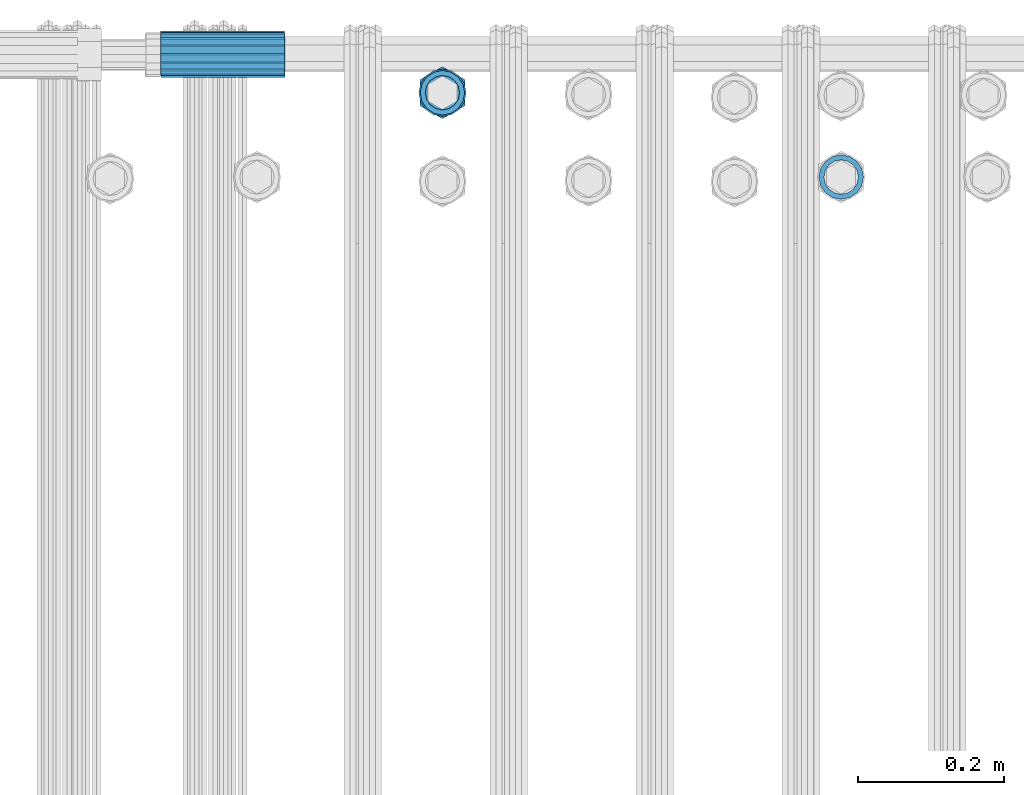
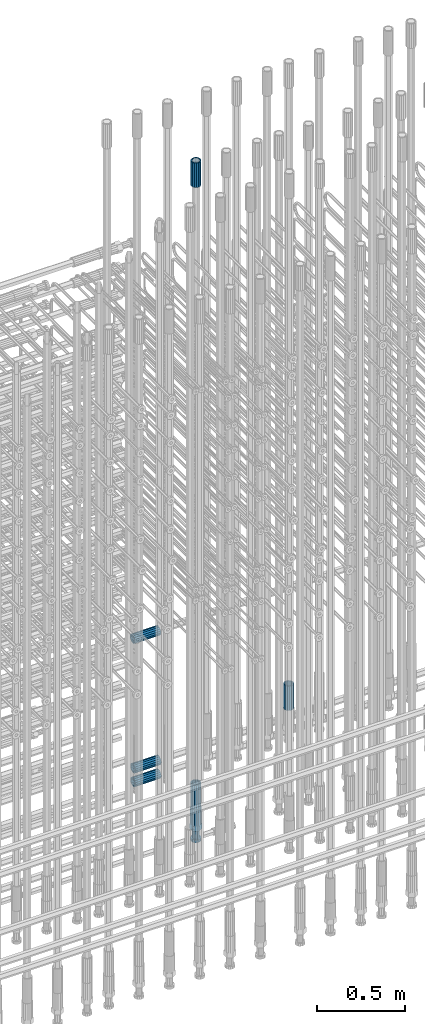
# One storey, part 70 of 177: 7 beams.
"""IFC2X3 building model written with IfcOpenShell, lengths in millimetres."""

from ifc_helpers import new_model, si_unit, frame, origin_with_axes, place, context, subcontext, project, spatial, faceted_brep, material, type_object, element, save


model = new_model("IFC2X3")

# Units and contexts
model_context_1 = context("Model", 3, precision=1e-05, world=origin_with_axes())
model_context_2 = context("Model", 3, precision=1e-05, world=origin_with_axes())
body_context = subcontext(model_context_2, "Body", "Model", "MODEL_VIEW")
ifc_project = project(units=[si_unit("LENGTHUNIT", "METRE", prefix="MILLI"), si_unit("AREAUNIT", "SQUARE_METRE"), si_unit("VOLUMEUNIT", "CUBIC_METRE"), si_unit("MASSUNIT", "GRAM", prefix="KILO"), si_unit("TIMEUNIT", "SECOND"), si_unit("PLANEANGLEUNIT", "RADIAN"), si_unit("SOLIDANGLEUNIT", "STERADIAN"), si_unit("THERMODYNAMICTEMPERATUREUNIT", "DEGREE_CELSIUS"), si_unit("LUMINOUSINTENSITYUNIT", "LUMEN")], contexts=[model_context_1])

# Site, building, storey
site_placement = place(None, origin_with_axes())
site = spatial("IfcSite", under=ifc_project, at=site_placement, CompositionType="ELEMENT")
building_placement = place(site_placement, origin_with_axes())
building = spatial("IfcBuilding", under=site, at=building_placement, Name="Undefined", CompositionType="ELEMENT")
storey_placement = place(building_placement, origin_with_axes())
storey = spatial("IfcBuildingStorey", under=building, at=storey_placement, Name="Undefined", CompositionType="ELEMENT", Elevation=0.0)

# Beams
ifc_material = material(Name="STEEL/S275")
beam_type_1 = type_object("IfcBeamType", PredefinedType="NOTDEFINED")
beam_1_placement = place(storey_placement, frame((2032235.99847313, 6206346.48588036, 18490.9668004296), z_axis=(-1.0, 0.0, 0.0), x_axis=(0.0, 0.0, -1.0)))
element("IfcBeam", 1, at=beam_1_placement, inside=storey, type_object=beam_type_1, material=ifc_material, Name="AG40N", context=body_context, shape_type="Brep", body=[
    faceted_brep([(0.0, -23.5000000001164, -9.31322574615479e-10), (0.0, -21.7111690140155, 8.99306066054851), (170.0, -21.7111690140155, 8.99306066054851), (170.0, -23.5, 0.0), (0.0, -16.6170093578839, 16.6170093575493), (170.0, -16.6170093578839, 16.6170093575493), (0.0, -8.99306066057943, 21.7111690137535), (170.0, -8.99306066057943, 21.7111690137535), (0.0, 1.16415321826935e-10, 23.5), (170.0, 0.0, 23.5), (0.0, 8.99306066057943, 21.7111690137535), (170.0, 8.99306066057943, 21.7111690137535), (0.0, 16.6170093578839, 16.6170093575493), (170.0, 16.6170093578839, 16.6170093575493), (0.0, 21.7111690140155, 8.99306066054851), (170.0, 21.7111690140155, 8.99306066054851), (0.0, 23.5000000001164, -9.31322574615479e-10), (170.0, 23.5, 0.0), (0.0, 21.7111690140155, -8.99306066054851), (170.0, 21.7111690140155, -8.99306066054851), (0.0, 16.6170093578839, -16.6170093575493), (170.0, 16.6170093578839, -16.6170093575493), (0.0, 8.99306066057943, -21.7111690137535), (170.0, 8.99306066057943, -21.7111690137535), (0.0, 1.16415321826935e-10, -23.5000000009313), (170.0, 0.0, -23.5), (0.0, -8.99306066057943, -21.7111690137535), (170.0, -8.99306066057943, -21.7111690137535), (0.0, -16.6170093578839, -16.6170093575493), (170.0, -16.6170093578839, -16.6170093575493), (0.0, -21.7111690140155, -8.99306066054851), (170.0, -21.7111690140155, -8.99306066054851), (0.0, -30.5, 0.0), (0.0, -28.1783257415937, -11.6718446873128), (170.0, -28.1783257415937, -11.6718446873128), (170.0, -30.5, 0.0), (0.0, -21.5667568261888, -21.5667568258941), (170.0, -21.5667568261888, -21.5667568258941), (0.0, -11.6718446871346, -28.1783257415518), (170.0, -11.6718446871346, -28.1783257415518), (0.0, 0.0, -30.5), (170.0, 0.0, -30.5), (0.0, 11.6718446871346, -28.1783257415518), (170.0, 11.6718446871346, -28.1783257415518), (0.0, 21.5667568261888, -21.5667568258941), (170.0, 21.5667568261888, -21.5667568258941), (0.0, 28.1783257415937, -11.6718446873128), (170.0, 28.1783257415937, -11.6718446873128), (0.0, 30.5, 0.0), (170.0, 30.5, 0.0), (0.0, 28.1783257415937, 11.6718446873128), (170.0, 28.1783257415937, 11.6718446873128), (0.0, 21.5667568261888, 21.5667568258941), (170.0, 21.5667568261888, 21.5667568258941), (0.0, 11.6718446871346, 28.1783257415518), (170.0, 11.6718446871346, 28.1783257415518), (0.0, 0.0, 30.5), (170.0, 0.0, 30.5), (0.0, -11.6718446871346, 28.1783257415518), (170.0, -11.6718446871346, 28.1783257415518), (0.0, -21.5667568261888, 21.5667568258941), (170.0, -21.5667568261888, 21.5667568258941), (0.0, -28.1783257415937, 11.6718446873128), (170.0, -28.1783257415937, 11.6718446873128)], [[[0, 1, 2, 3]], [[1, 4, 5, 2]], [[4, 6, 7, 5]], [[6, 8, 9, 7]], [[8, 10, 11, 9]], [[10, 12, 13, 11]], [[12, 14, 15, 13]], [[14, 16, 17, 15]], [[16, 18, 19, 17]], [[18, 20, 21, 19]], [[20, 22, 23, 21]], [[22, 24, 25, 23]], [[24, 26, 27, 25]], [[26, 28, 29, 27]], [[28, 30, 31, 29]], [[30, 0, 3, 31]], [[32, 33, 34, 35]], [[33, 36, 37, 34]], [[36, 38, 39, 37]], [[38, 40, 41, 39]], [[40, 42, 43, 41]], [[42, 44, 45, 43]], [[44, 46, 47, 45]], [[46, 48, 49, 47]], [[48, 50, 51, 49]], [[50, 52, 53, 51]], [[52, 54, 55, 53]], [[54, 56, 57, 55]], [[56, 58, 59, 57]], [[58, 60, 61, 59]], [[60, 62, 63, 61]], [[62, 32, 35, 63]], [[37, 39, 41, 43, 45, 47, 49, 51, 53, 55, 57, 59, 61, 63, 35, 34], [5, 7, 9, 11, 13, 15, 17, 19, 21, 23, 25, 27, 29, 31, 3, 2]], [[62, 60, 58, 56, 54, 52, 50, 48, 46, 44, 42, 40, 38, 36, 33, 32], [30, 28, 26, 24, 22, 20, 18, 16, 14, 12, 10, 8, 6, 4, 1, 0]]]),
])
beam_2_placement = place(storey_placement, frame((2032235.99847313, 6206346.48588036, 22659.9858194828), z_axis=(1.0, 0.0, 0.0), x_axis=(0.0, 0.0, 1.0)))
element("IfcBeam", 2, at=beam_2_placement, inside=storey, type_object=beam_type_1, material=ifc_material, Name="AG40N", context=body_context, shape_type="Brep", body=[
    faceted_brep([(0.0, -23.5000000001164, -9.31322574615479e-10), (0.0, -21.7111690140155, 8.99306066054851), (170.0, -21.7111690140155, 8.99306066054851), (170.0, -23.5, 0.0), (0.0, -16.6170093578839, 16.6170093575493), (170.0, -16.6170093578839, 16.6170093575493), (0.0, -8.99306066057943, 21.7111690137535), (170.0, -8.99306066057943, 21.7111690137535), (0.0, 1.16415321826935e-10, 23.5), (170.0, 0.0, 23.5), (0.0, 8.99306066057943, 21.7111690137535), (170.0, 8.99306066057943, 21.7111690137535), (0.0, 16.6170093578839, 16.6170093575493), (170.0, 16.6170093578839, 16.6170093575493), (0.0, 21.7111690140155, 8.99306066054851), (170.0, 21.7111690140155, 8.99306066054851), (0.0, 23.5000000001164, -9.31322574615479e-10), (170.0, 23.5, 0.0), (0.0, 21.7111690140155, -8.99306066054851), (170.0, 21.7111690140155, -8.99306066054851), (0.0, 16.6170093578839, -16.6170093575493), (170.0, 16.6170093578839, -16.6170093575493), (0.0, 8.99306066057943, -21.7111690137535), (170.0, 8.99306066057943, -21.7111690137535), (0.0, 1.16415321826935e-10, -23.5000000009313), (170.0, 0.0, -23.5), (0.0, -8.99306066057943, -21.7111690137535), (170.0, -8.99306066057943, -21.7111690137535), (0.0, -16.6170093578839, -16.6170093575493), (170.0, -16.6170093578839, -16.6170093575493), (0.0, -21.7111690140155, -8.99306066054851), (170.0, -21.7111690140155, -8.99306066054851), (0.0, -30.5, 0.0), (0.0, -28.1783257415937, -11.6718446873128), (170.0, -28.1783257415937, -11.6718446873128), (170.0, -30.5, 0.0), (0.0, -21.5667568261888, -21.5667568258941), (170.0, -21.5667568261888, -21.5667568258941), (0.0, -11.6718446871346, -28.1783257415518), (170.0, -11.6718446871346, -28.1783257415518), (0.0, 0.0, -30.5), (170.0, 0.0, -30.5), (0.0, 11.6718446871346, -28.1783257415518), (170.0, 11.6718446871346, -28.1783257415518), (0.0, 21.5667568261888, -21.5667568258941), (170.0, 21.5667568261888, -21.5667568258941), (0.0, 28.1783257415937, -11.6718446873128), (170.0, 28.1783257415937, -11.6718446873128), (0.0, 30.5, 0.0), (170.0, 30.5, 0.0), (0.0, 28.1783257415937, 11.6718446873128), (170.0, 28.1783257415937, 11.6718446873128), (0.0, 21.5667568261888, 21.5667568258941), (170.0, 21.5667568261888, 21.5667568258941), (0.0, 11.6718446871346, 28.1783257415518), (170.0, 11.6718446871346, 28.1783257415518), (0.0, 0.0, 30.5), (170.0, 0.0, 30.5), (0.0, -11.6718446871346, 28.1783257415518), (170.0, -11.6718446871346, 28.1783257415518), (0.0, -21.5667568261888, 21.5667568258941), (170.0, -21.5667568261888, 21.5667568258941), (0.0, -28.1783257415937, 11.6718446873128), (170.0, -28.1783257415937, 11.6718446873128)], [[[0, 1, 2, 3]], [[1, 4, 5, 2]], [[4, 6, 7, 5]], [[6, 8, 9, 7]], [[8, 10, 11, 9]], [[10, 12, 13, 11]], [[12, 14, 15, 13]], [[14, 16, 17, 15]], [[16, 18, 19, 17]], [[18, 20, 21, 19]], [[20, 22, 23, 21]], [[22, 24, 25, 23]], [[24, 26, 27, 25]], [[26, 28, 29, 27]], [[28, 30, 31, 29]], [[30, 0, 3, 31]], [[32, 33, 34, 35]], [[33, 36, 37, 34]], [[36, 38, 39, 37]], [[38, 40, 41, 39]], [[40, 42, 43, 41]], [[42, 44, 45, 43]], [[44, 46, 47, 45]], [[46, 48, 49, 47]], [[48, 50, 51, 49]], [[50, 52, 53, 51]], [[52, 54, 55, 53]], [[54, 56, 57, 55]], [[56, 58, 59, 57]], [[58, 60, 61, 59]], [[60, 62, 63, 61]], [[62, 32, 35, 63]], [[37, 39, 41, 43, 45, 47, 49, 51, 53, 55, 57, 59, 61, 63, 35, 34], [5, 7, 9, 11, 13, 15, 17, 19, 21, 23, 25, 27, 29, 31, 3, 2]], [[62, 60, 58, 56, 54, 52, 50, 48, 46, 44, 42, 40, 38, 36, 33, 32], [30, 28, 26, 24, 22, 20, 18, 16, 14, 12, 10, 8, 6, 4, 1, 0]]]),
])
beam_3_placement = place(storey_placement, frame((2032019.99847313, 6206400.48588036, 19594.9868004306), z_axis=(0.0, 0.0, -1.0), x_axis=(-1.0, 0.0, 0.0)))
element("IfcBeam", 3, at=beam_3_placement, inside=storey, type_object=beam_type_1, material=ifc_material, Name="AG40N", context=body_context, shape_type="Brep", body=[
    faceted_brep([(0.0, -23.5000000001164, -9.31322574615479e-10), (0.0, -21.7111690140155, 8.99306066054851), (170.0, -21.7111690140155, 8.99306066054851), (170.0, -23.5, 0.0), (0.0, -16.6170093578839, 16.6170093575493), (170.0, -16.6170093578839, 16.6170093575493), (0.0, -8.99306066057943, 21.7111690137535), (170.0, -8.99306066057943, 21.7111690137535), (0.0, 1.16415321826935e-10, 23.5), (170.0, 0.0, 23.5), (0.0, 8.99306066057943, 21.7111690137535), (170.0, 8.99306066057943, 21.7111690137535), (0.0, 16.6170093578839, 16.6170093575493), (170.0, 16.6170093578839, 16.6170093575493), (0.0, 21.7111690140155, 8.99306066054851), (170.0, 21.7111690140155, 8.99306066054851), (0.0, 23.5000000001164, -9.31322574615479e-10), (170.0, 23.5, 0.0), (0.0, 21.7111690140155, -8.99306066054851), (170.0, 21.7111690140155, -8.99306066054851), (0.0, 16.6170093578839, -16.6170093575493), (170.0, 16.6170093578839, -16.6170093575493), (0.0, 8.99306066057943, -21.7111690137535), (170.0, 8.99306066057943, -21.7111690137535), (0.0, 1.16415321826935e-10, -23.5000000009313), (170.0, 0.0, -23.5), (0.0, -8.99306066057943, -21.7111690137535), (170.0, -8.99306066057943, -21.7111690137535), (0.0, -16.6170093578839, -16.6170093575493), (170.0, -16.6170093578839, -16.6170093575493), (0.0, -21.7111690140155, -8.99306066054851), (170.0, -21.7111690140155, -8.99306066054851), (0.0, -30.5, 0.0), (0.0, -28.1783257415937, -11.6718446873128), (170.0, -28.1783257415937, -11.6718446873128), (170.0, -30.5, 0.0), (0.0, -21.5667568261888, -21.5667568258941), (170.0, -21.5667568261888, -21.5667568258941), (0.0, -11.6718446871346, -28.1783257415518), (170.0, -11.6718446871346, -28.1783257415518), (0.0, 0.0, -30.5), (170.0, 0.0, -30.5), (0.0, 11.6718446871346, -28.1783257415518), (170.0, 11.6718446871346, -28.1783257415518), (0.0, 21.5667568261888, -21.5667568258941), (170.0, 21.5667568261888, -21.5667568258941), (0.0, 28.1783257415937, -11.6718446873128), (170.0, 28.1783257415937, -11.6718446873128), (0.0, 30.5, 0.0), (170.0, 30.5, 0.0), (0.0, 28.1783257415937, 11.6718446873128), (170.0, 28.1783257415937, 11.6718446873128), (0.0, 21.5667568261888, 21.5667568258941), (170.0, 21.5667568261888, 21.5667568258941), (0.0, 11.6718446871346, 28.1783257415518), (170.0, 11.6718446871346, 28.1783257415518), (0.0, 0.0, 30.5), (170.0, 0.0, 30.5), (0.0, -11.6718446871346, 28.1783257415518), (170.0, -11.6718446871346, 28.1783257415518), (0.0, -21.5667568261888, 21.5667568258941), (170.0, -21.5667568261888, 21.5667568258941), (0.0, -28.1783257415937, 11.6718446873128), (170.0, -28.1783257415937, 11.6718446873128)], [[[0, 1, 2, 3]], [[1, 4, 5, 2]], [[4, 6, 7, 5]], [[6, 8, 9, 7]], [[8, 10, 11, 9]], [[10, 12, 13, 11]], [[12, 14, 15, 13]], [[14, 16, 17, 15]], [[16, 18, 19, 17]], [[18, 20, 21, 19]], [[20, 22, 23, 21]], [[22, 24, 25, 23]], [[24, 26, 27, 25]], [[26, 28, 29, 27]], [[28, 30, 31, 29]], [[30, 0, 3, 31]], [[32, 33, 34, 35]], [[33, 36, 37, 34]], [[36, 38, 39, 37]], [[38, 40, 41, 39]], [[40, 42, 43, 41]], [[42, 44, 45, 43]], [[44, 46, 47, 45]], [[46, 48, 49, 47]], [[48, 50, 51, 49]], [[50, 52, 53, 51]], [[52, 54, 55, 53]], [[54, 56, 57, 55]], [[56, 58, 59, 57]], [[58, 60, 61, 59]], [[60, 62, 63, 61]], [[62, 32, 35, 63]], [[37, 39, 41, 43, 45, 47, 49, 51, 53, 55, 57, 59, 61, 63, 35, 34], [5, 7, 9, 11, 13, 15, 17, 19, 21, 23, 25, 27, 29, 31, 3, 2]], [[62, 60, 58, 56, 54, 52, 50, 48, 46, 44, 42, 40, 38, 36, 33, 32], [30, 28, 26, 24, 22, 20, 18, 16, 14, 12, 10, 8, 6, 4, 1, 0]]]),
])
beam_4_placement = place(storey_placement, frame((2032020.49847313, 6206397.98588036, 18597.2968004168), z_axis=(0.0, 0.0, -1.0), x_axis=(-1.0, 0.0, 0.0)))
element("IfcBeam", 4, at=beam_4_placement, inside=storey, type_object=beam_type_1, material=ifc_material, Name="AG40N", context=body_context, shape_type="Brep", body=[
    faceted_brep([(0.0, -23.5000000001164, -9.31322574615479e-10), (0.0, -21.7111690140155, 8.99306066054851), (170.0, -21.7111690140155, 8.99306066054851), (170.0, -23.5, 0.0), (0.0, -16.6170093578839, 16.6170093575493), (170.0, -16.6170093578839, 16.6170093575493), (0.0, -8.99306066057943, 21.7111690137535), (170.0, -8.99306066057943, 21.7111690137535), (0.0, 1.16415321826935e-10, 23.5), (170.0, 0.0, 23.5), (0.0, 8.99306066057943, 21.7111690137535), (170.0, 8.99306066057943, 21.7111690137535), (0.0, 16.6170093578839, 16.6170093575493), (170.0, 16.6170093578839, 16.6170093575493), (0.0, 21.7111690140155, 8.99306066054851), (170.0, 21.7111690140155, 8.99306066054851), (0.0, 23.5000000001164, -9.31322574615479e-10), (170.0, 23.5, 0.0), (0.0, 21.7111690140155, -8.99306066054851), (170.0, 21.7111690140155, -8.99306066054851), (0.0, 16.6170093578839, -16.6170093575493), (170.0, 16.6170093578839, -16.6170093575493), (0.0, 8.99306066057943, -21.7111690137535), (170.0, 8.99306066057943, -21.7111690137535), (0.0, 1.16415321826935e-10, -23.5000000009313), (170.0, 0.0, -23.5), (0.0, -8.99306066057943, -21.7111690137535), (170.0, -8.99306066057943, -21.7111690137535), (0.0, -16.6170093578839, -16.6170093575493), (170.0, -16.6170093578839, -16.6170093575493), (0.0, -21.7111690140155, -8.99306066054851), (170.0, -21.7111690140155, -8.99306066054851), (0.0, -30.5, 0.0), (0.0, -28.1783257415937, -11.6718446873128), (170.0, -28.1783257415937, -11.6718446873128), (170.0, -30.5, 0.0), (0.0, -21.5667568261888, -21.5667568258941), (170.0, -21.5667568261888, -21.5667568258941), (0.0, -11.6718446871346, -28.1783257415518), (170.0, -11.6718446871346, -28.1783257415518), (0.0, 0.0, -30.5), (170.0, 0.0, -30.5), (0.0, 11.6718446871346, -28.1783257415518), (170.0, 11.6718446871346, -28.1783257415518), (0.0, 21.5667568261888, -21.5667568258941), (170.0, 21.5667568261888, -21.5667568258941), (0.0, 28.1783257415937, -11.6718446873128), (170.0, 28.1783257415937, -11.6718446873128), (0.0, 30.5, 0.0), (170.0, 30.5, 0.0), (0.0, 28.1783257415937, 11.6718446873128), (170.0, 28.1783257415937, 11.6718446873128), (0.0, 21.5667568261888, 21.5667568258941), (170.0, 21.5667568261888, 21.5667568258941), (0.0, 11.6718446871346, 28.1783257415518), (170.0, 11.6718446871346, 28.1783257415518), (0.0, 0.0, 30.5), (170.0, 0.0, 30.5), (0.0, -11.6718446871346, 28.1783257415518), (170.0, -11.6718446871346, 28.1783257415518), (0.0, -21.5667568261888, 21.5667568258941), (170.0, -21.5667568261888, 21.5667568258941), (0.0, -28.1783257415937, 11.6718446873128), (170.0, -28.1783257415937, 11.6718446873128)], [[[0, 1, 2, 3]], [[1, 4, 5, 2]], [[4, 6, 7, 5]], [[6, 8, 9, 7]], [[8, 10, 11, 9]], [[10, 12, 13, 11]], [[12, 14, 15, 13]], [[14, 16, 17, 15]], [[16, 18, 19, 17]], [[18, 20, 21, 19]], [[20, 22, 23, 21]], [[22, 24, 25, 23]], [[24, 26, 27, 25]], [[26, 28, 29, 27]], [[28, 30, 31, 29]], [[30, 0, 3, 31]], [[32, 33, 34, 35]], [[33, 36, 37, 34]], [[36, 38, 39, 37]], [[38, 40, 41, 39]], [[40, 42, 43, 41]], [[42, 44, 45, 43]], [[44, 46, 47, 45]], [[46, 48, 49, 47]], [[48, 50, 51, 49]], [[50, 52, 53, 51]], [[52, 54, 55, 53]], [[54, 56, 57, 55]], [[56, 58, 59, 57]], [[58, 60, 61, 59]], [[60, 62, 63, 61]], [[62, 32, 35, 63]], [[37, 39, 41, 43, 45, 47, 49, 51, 53, 55, 57, 59, 61, 63, 35, 34], [5, 7, 9, 11, 13, 15, 17, 19, 21, 23, 25, 27, 29, 31, 3, 2]], [[62, 60, 58, 56, 54, 52, 50, 48, 46, 44, 42, 40, 38, 36, 33, 32], [30, 28, 26, 24, 22, 20, 18, 16, 14, 12, 10, 8, 6, 4, 1, 0]]]),
])
beam_5_placement = place(storey_placement, frame((2032020.49847313, 6206397.98588036, 18692.9968004304), z_axis=(0.0, 0.0, -1.0), x_axis=(-1.0, 0.0, 0.0)))
element("IfcBeam", 5, at=beam_5_placement, inside=storey, type_object=beam_type_1, material=ifc_material, Name="AG40N", context=body_context, shape_type="Brep", body=[
    faceted_brep([(0.0, -23.5000000001164, -9.31322574615479e-10), (0.0, -21.7111690140155, 8.99306066054851), (170.0, -21.7111690140155, 8.99306066054851), (170.0, -23.5, 0.0), (0.0, -16.6170093578839, 16.6170093575493), (170.0, -16.6170093578839, 16.6170093575493), (0.0, -8.99306066057943, 21.7111690137535), (170.0, -8.99306066057943, 21.7111690137535), (0.0, 1.16415321826935e-10, 23.5), (170.0, 0.0, 23.5), (0.0, 8.99306066057943, 21.7111690137535), (170.0, 8.99306066057943, 21.7111690137535), (0.0, 16.6170093578839, 16.6170093575493), (170.0, 16.6170093578839, 16.6170093575493), (0.0, 21.7111690140155, 8.99306066054851), (170.0, 21.7111690140155, 8.99306066054851), (0.0, 23.5000000001164, -9.31322574615479e-10), (170.0, 23.5, 0.0), (0.0, 21.7111690140155, -8.99306066054851), (170.0, 21.7111690140155, -8.99306066054851), (0.0, 16.6170093578839, -16.6170093575493), (170.0, 16.6170093578839, -16.6170093575493), (0.0, 8.99306066057943, -21.7111690137535), (170.0, 8.99306066057943, -21.7111690137535), (0.0, 1.16415321826935e-10, -23.5000000009313), (170.0, 0.0, -23.5), (0.0, -8.99306066057943, -21.7111690137535), (170.0, -8.99306066057943, -21.7111690137535), (0.0, -16.6170093578839, -16.6170093575493), (170.0, -16.6170093578839, -16.6170093575493), (0.0, -21.7111690140155, -8.99306066054851), (170.0, -21.7111690140155, -8.99306066054851), (0.0, -30.5, 0.0), (0.0, -28.1783257415937, -11.6718446873128), (170.0, -28.1783257415937, -11.6718446873128), (170.0, -30.5, 0.0), (0.0, -21.5667568261888, -21.5667568258941), (170.0, -21.5667568261888, -21.5667568258941), (0.0, -11.6718446871346, -28.1783257415518), (170.0, -11.6718446871346, -28.1783257415518), (0.0, 0.0, -30.5), (170.0, 0.0, -30.5), (0.0, 11.6718446871346, -28.1783257415518), (170.0, 11.6718446871346, -28.1783257415518), (0.0, 21.5667568261888, -21.5667568258941), (170.0, 21.5667568261888, -21.5667568258941), (0.0, 28.1783257415937, -11.6718446873128), (170.0, 28.1783257415937, -11.6718446873128), (0.0, 30.5, 0.0), (170.0, 30.5, 0.0), (0.0, 28.1783257415937, 11.6718446873128), (170.0, 28.1783257415937, 11.6718446873128), (0.0, 21.5667568261888, 21.5667568258941), (170.0, 21.5667568261888, 21.5667568258941), (0.0, 11.6718446871346, 28.1783257415518), (170.0, 11.6718446871346, 28.1783257415518), (0.0, 0.0, 30.5), (170.0, 0.0, 30.5), (0.0, -11.6718446871346, 28.1783257415518), (170.0, -11.6718446871346, 28.1783257415518), (0.0, -21.5667568261888, 21.5667568258941), (170.0, -21.5667568261888, 21.5667568258941), (0.0, -28.1783257415937, 11.6718446873128), (170.0, -28.1783257415937, 11.6718446873128)], [[[0, 1, 2, 3]], [[1, 4, 5, 2]], [[4, 6, 7, 5]], [[6, 8, 9, 7]], [[8, 10, 11, 9]], [[10, 12, 13, 11]], [[12, 14, 15, 13]], [[14, 16, 17, 15]], [[16, 18, 19, 17]], [[18, 20, 21, 19]], [[20, 22, 23, 21]], [[22, 24, 25, 23]], [[24, 26, 27, 25]], [[26, 28, 29, 27]], [[28, 30, 31, 29]], [[30, 0, 3, 31]], [[32, 33, 34, 35]], [[33, 36, 37, 34]], [[36, 38, 39, 37]], [[38, 40, 41, 39]], [[40, 42, 43, 41]], [[42, 44, 45, 43]], [[44, 46, 47, 45]], [[46, 48, 49, 47]], [[48, 50, 51, 49]], [[50, 52, 53, 51]], [[52, 54, 55, 53]], [[54, 56, 57, 55]], [[56, 58, 59, 57]], [[58, 60, 61, 59]], [[60, 62, 63, 61]], [[62, 32, 35, 63]], [[37, 39, 41, 43, 45, 47, 49, 51, 53, 55, 57, 59, 61, 63, 35, 34], [5, 7, 9, 11, 13, 15, 17, 19, 21, 23, 25, 27, 29, 31, 3, 2]], [[62, 60, 58, 56, 54, 52, 50, 48, 46, 44, 42, 40, 38, 36, 33, 32], [30, 28, 26, 24, 22, 20, 18, 16, 14, 12, 10, 8, 6, 4, 1, 0]]]),
])
beam_6_placement = place(storey_placement, frame((2032781.99847313, 6206230.98588036, 19060.9668004296), z_axis=(-1.0, 0.0, 0.0), x_axis=(0.0, 0.0, -1.0)))
element("IfcBeam", 6, at=beam_6_placement, inside=storey, type_object=beam_type_1, material=ifc_material, Name="AG40N", context=body_context, shape_type="Brep", body=[
    faceted_brep([(0.0, -23.5000000001164, -9.31322574615479e-10), (0.0, -21.7111690140155, 8.99306066054851), (170.0, -21.7111690140155, 8.99306066054851), (170.0, -23.5, 0.0), (0.0, -16.6170093578839, 16.6170093575493), (170.0, -16.6170093578839, 16.6170093575493), (0.0, -8.99306066057943, 21.7111690137535), (170.0, -8.99306066057943, 21.7111690137535), (0.0, 1.16415321826935e-10, 23.5), (170.0, 0.0, 23.5), (0.0, 8.99306066057943, 21.7111690137535), (170.0, 8.99306066057943, 21.7111690137535), (0.0, 16.6170093578839, 16.6170093575493), (170.0, 16.6170093578839, 16.6170093575493), (0.0, 21.7111690140155, 8.99306066054851), (170.0, 21.7111690140155, 8.99306066054851), (0.0, 23.5000000001164, -9.31322574615479e-10), (170.0, 23.5, 0.0), (0.0, 21.7111690140155, -8.99306066054851), (170.0, 21.7111690140155, -8.99306066054851), (0.0, 16.6170093578839, -16.6170093575493), (170.0, 16.6170093578839, -16.6170093575493), (0.0, 8.99306066057943, -21.7111690137535), (170.0, 8.99306066057943, -21.7111690137535), (0.0, 1.16415321826935e-10, -23.5000000009313), (170.0, 0.0, -23.5), (0.0, -8.99306066057943, -21.7111690137535), (170.0, -8.99306066057943, -21.7111690137535), (0.0, -16.6170093578839, -16.6170093575493), (170.0, -16.6170093578839, -16.6170093575493), (0.0, -21.7111690140155, -8.99306066054851), (170.0, -21.7111690140155, -8.99306066054851), (0.0, -30.5, 0.0), (0.0, -28.1783257415937, -11.6718446873128), (170.0, -28.1783257415937, -11.6718446873128), (170.0, -30.5, 0.0), (0.0, -21.5667568261888, -21.5667568258941), (170.0, -21.5667568261888, -21.5667568258941), (0.0, -11.6718446871346, -28.1783257415518), (170.0, -11.6718446871346, -28.1783257415518), (0.0, 0.0, -30.5), (170.0, 0.0, -30.5), (0.0, 11.6718446871346, -28.1783257415518), (170.0, 11.6718446871346, -28.1783257415518), (0.0, 21.5667568261888, -21.5667568258941), (170.0, 21.5667568261888, -21.5667568258941), (0.0, 28.1783257415937, -11.6718446873128), (170.0, 28.1783257415937, -11.6718446873128), (0.0, 30.5, 0.0), (170.0, 30.5, 0.0), (0.0, 28.1783257415937, 11.6718446873128), (170.0, 28.1783257415937, 11.6718446873128), (0.0, 21.5667568261888, 21.5667568258941), (170.0, 21.5667568261888, 21.5667568258941), (0.0, 11.6718446871346, 28.1783257415518), (170.0, 11.6718446871346, 28.1783257415518), (0.0, 0.0, 30.5), (170.0, 0.0, 30.5), (0.0, -11.6718446871346, 28.1783257415518), (170.0, -11.6718446871346, 28.1783257415518), (0.0, -21.5667568261888, 21.5667568258941), (170.0, -21.5667568261888, 21.5667568258941), (0.0, -28.1783257415937, 11.6718446873128), (170.0, -28.1783257415937, 11.6718446873128)], [[[0, 1, 2, 3]], [[1, 4, 5, 2]], [[4, 6, 7, 5]], [[6, 8, 9, 7]], [[8, 10, 11, 9]], [[10, 12, 13, 11]], [[12, 14, 15, 13]], [[14, 16, 17, 15]], [[16, 18, 19, 17]], [[18, 20, 21, 19]], [[20, 22, 23, 21]], [[22, 24, 25, 23]], [[24, 26, 27, 25]], [[26, 28, 29, 27]], [[28, 30, 31, 29]], [[30, 0, 3, 31]], [[32, 33, 34, 35]], [[33, 36, 37, 34]], [[36, 38, 39, 37]], [[38, 40, 41, 39]], [[40, 42, 43, 41]], [[42, 44, 45, 43]], [[44, 46, 47, 45]], [[46, 48, 49, 47]], [[48, 50, 51, 49]], [[50, 52, 53, 51]], [[52, 54, 55, 53]], [[54, 56, 57, 55]], [[56, 58, 59, 57]], [[58, 60, 61, 59]], [[60, 62, 63, 61]], [[62, 32, 35, 63]], [[37, 39, 41, 43, 45, 47, 49, 51, 53, 55, 57, 59, 61, 63, 35, 34], [5, 7, 9, 11, 13, 15, 17, 19, 21, 23, 25, 27, 29, 31, 3, 2]], [[62, 60, 58, 56, 54, 52, 50, 48, 46, 44, 42, 40, 38, 36, 33, 32], [30, 28, 26, 24, 22, 20, 18, 16, 14, 12, 10, 8, 6, 4, 1, 0]]]),
])
beam_type_2 = type_object("IfcBeamType", Name="ROD65", PredefinedType="NOTDEFINED")
beam_7_placement = place(storey_placement, frame((2032235.99847313, 6206346.48588036, 18320.9668004296), z_axis=(-1.0, 0.0, 0.0), x_axis=(0.0, 0.0, -1.0)))
element("IfcBeam", 7, at=beam_7_placement, inside=storey, type_object=beam_type_2, material=ifc_material, Name="AGB40", ObjectType="ROD65", context=body_context, shape_type="Brep", body=[
    faceted_brep([(117.0, 8.17543110251427, 30.873805644922), (117.0, 17.8250000001863, 30.873805644922), (117.0, 22.0056958701462, 23.6326279877685), (117.0, 12.4372115517035, 30.0260848065373), (117.0, -17.8250000001863, 30.873805644922), (150.200000000186, -17.8250000001863, 30.873805644922), (150.200000000186, 17.8250000001863, 30.873805644922), (117.0, -8.17543110251427, 30.873805644922), (117.0, -12.4372115517035, 30.0260848065373), (117.0, -22.0056958701462, 23.6326279877685), (117.0, -35.6500000003725, 0.0), (150.200000000186, -35.6500000003725, 0.0), (117.0, -30.8443150008097, 8.32369058486074), (117.0, -32.5, 0.0), (117.0, -30.8443150008097, -8.32369058462791), (117.0, -17.8250000001863, -30.873805644922), (150.200000000186, -17.8250000001863, -30.873805644922), (117.0, -22.0056958701462, -23.6326279877685), (117.0, -12.4372115517035, -30.0260848065373), (117.0, -8.17543110251427, -30.873805644922), (117.0, 17.8250000001863, -30.873805644922), (150.200000000186, 17.8250000001863, -30.873805644922), (117.0, 8.17543110251427, -30.873805644922), (117.0, 22.0056958701462, -23.6326279877685), (117.0, 12.4372115517035, -30.0260848065373), (117.0, 35.6500000003725, 0.0), (150.200000000186, 35.6500000003725, 0.0), (117.0, 30.8443150008097, -8.32369058486074), (117.0, 30.8443150008097, 8.32369058462791), (117.0, 32.5, 0.0), (0.0, -22.9809703892097, 22.9809703885621), (0.0, -30.0260848058388, 12.4372115518636), (117.0, -30.0260848067701, 12.4372115519363), (117.0, -22.9809703882784, 22.9809703885112), (-2.3283064365387e-10, 22.9809703892097, -22.9809703885639), (-4.65661287307739e-10, 30.0260848077014, -12.4372115518672), (117.0, 30.0260848067701, -12.4372115519363), (117.0, 22.9809703882784, -22.9809703885112), (-2.3283064365387e-10, -30.0260848067701, -12.4372115518672), (-2.3283064365387e-10, -22.9809703892097, -22.9809703885621), (117.0, -22.9809703882784, -22.9809703885112), (117.0, -30.0260848067701, -12.4372115519363), (-2.3283064365387e-10, -12.4372115507722, 30.0260848066137), (-2.3283064365387e-10, 9.31322574615479e-10, 32.4999999999982), (-2.3283064365387e-10, 12.4372115526348, 30.0260848066137), (0.0, 22.9809703892097, 22.9809703885621), (-2.3283064365387e-10, 30.0260848077014, 12.4372115518636), (-2.3283064365387e-10, 32.5, 0.0), (-2.3283064365387e-10, 12.4372115526348, -30.0260848066173), (-2.3283064365387e-10, 9.31322574615479e-10, -32.5), (-2.3283064365387e-10, -12.4372115517035, -30.0260848066173), (-4.65661287307739e-10, -32.4999999990687, -1.81898940354586e-12), (117.0, 22.9809703882784, 22.9809703885112), (117.0, 30.0260848067701, 12.4372115519363), (117.0, 0.0, -32.5), (117.0, 0.0, 32.5), (150.200000000186, 10.5, -18.1865334794857), (150.200000000186, 0.0, -21.0), (150.200000000186, -10.5, -18.1865334794857), (150.200000000186, -18.18653347902, -10.5), (150.200000000186, -21.0, 0.0), (150.200000000186, -18.18653347902, 10.5), (150.200000000186, -10.5, 18.1865334794857), (150.200000000186, 0.0, 21.0), (150.200000000186, 10.5, 18.1865334794857), (150.200000000186, 18.18653347902, 10.5), (150.200000000186, 21.0, 0.0), (150.200000000186, 18.18653347902, -10.5), (210.980000000447, -10.5, -18.1865334794857), (210.980000000447, 0.0, -21.0), (210.980000000447, -18.18653347902, -10.5), (210.980000000447, -21.0, 0.0), (210.980000000447, -18.18653347902, 10.5), (210.980000000447, -10.5, 18.1865334794857), (210.980000000447, 0.0, 21.0), (210.980000000447, 10.5, 18.1865334794857), (210.980000000447, 18.18653347902, 10.5), (210.980000000447, 21.0, 0.0), (210.980000000447, 18.18653347902, -10.5), (210.980000000447, 10.5, -18.1865334794857), (211.001368442696, -27.7269937992096, -11.491116326768), (211.003082550167, -21.2238094303757, -21.223815418547), (231.002518367059, -21.2131944671273, -21.2132004550658), (231.000804259587, -27.7163788359612, -11.4805013632867), (211.001368440451, -11.4911085031927, -27.7269970395137), (231.000804257343, -11.4804935399443, -27.7163820760325), (210.996487071217, -0.0106065049767494, -30.0106107392348), (230.995922888109, 8.45827162265778e-06, -29.9999957757536), (210.989181586672, 11.46989420522, -27.7269970329944), (230.988617403564, 11.4805091684684, -27.7163820695132), (210.980564180623, 21.2025914648548, -21.2238154064398), (230.979999997515, 21.2132064281031, -21.2132004429586), (210.971946775022, 27.7057703435421, -11.4911163107026), (230.971382591913, 27.7163853067905, -11.4805013472214), (210.96464129175, 29.9893808094785, -0.0106149562634528), (230.964077108642, 29.9999957727268, 7.21774995326996e-09), (210.959759924415, 27.7057638689876, 11.4698863970116), (230.959195741307, 27.7163788322359, 11.4805013604928), (210.958045816944, 21.2025795001537, 21.2025854887906), (230.957481633835, 21.213194463402, 21.2132004522718), (210.95975992666, 11.4698785729706, 27.7057671097573), (230.959195743551, 11.480493536219, 27.7163820732385), (210.964641295894, -0.010623425245285, 29.9893808094785), (230.964077112785, -8.46199691295624e-06, 29.9999957729597), (210.971946780439, -11.4911241354421, 27.705767103238), (230.97138259733, -11.4805091721937, 27.7163820667192), (210.980564186488, -21.2238213950768, 21.2025854766835), (230.980000003379, -21.2132064318284, 21.2132004401647), (210.989181592089, -27.7270002737641, 11.4698863809463), (230.988617408981, -27.7163853105158, 11.4805013444275), (210.996487075361, -30.0106107397005, -0.0106149734929204), (230.995922892253, -29.9999957764521, -1.00117176771164e-08)], [[[0, 1, 2, 3]], [[4, 5, 6, 1, 0, 7]], [[4, 7, 8, 9]], [[10, 11, 5, 4, 9, 12]], [[10, 12, 13, 14]], [[15, 16, 11, 10, 14, 17]], [[15, 17, 18, 19]], [[20, 21, 16, 15, 19, 22]], [[23, 20, 22, 24]], [[25, 26, 21, 20, 23, 27]], [[28, 25, 27, 29]], [[30, 31, 32, 33]], [[34, 35, 36, 37]], [[38, 39, 40, 41]], [[31, 30, 42, 43, 44, 45, 46, 47, 35, 34, 48, 49, 50, 39, 38, 51]], [[46, 45, 52, 53]], [[29, 47, 46, 53, 28]], [[27, 36, 35, 47, 29]], [[23, 37, 36, 27]], [[24, 48, 34, 37, 23]], [[22, 54, 49, 48, 24]], [[19, 54, 22]], [[18, 50, 49, 54, 19]], [[17, 40, 39, 50, 18]], [[14, 41, 40, 17]], [[13, 51, 38, 41, 14]], [[12, 32, 31, 51, 13]], [[9, 33, 32, 12]], [[8, 42, 30, 33, 9]], [[7, 55, 43, 42, 8]], [[0, 55, 7]], [[3, 44, 43, 55, 0]], [[2, 52, 45, 44, 3]], [[28, 53, 52, 2]], [[1, 6, 26, 25, 28, 2]], [[5, 11, 16, 21, 26, 6], [56, 57, 58, 59, 60, 61, 62, 63, 64, 65, 66, 67]], [[68, 58, 57, 69]], [[70, 59, 58, 68]], [[71, 60, 59, 70]], [[72, 61, 60, 71]], [[73, 62, 61, 72]], [[74, 63, 62, 73]], [[75, 64, 63, 74]], [[76, 65, 64, 75]], [[77, 66, 65, 76]], [[78, 67, 66, 77]], [[79, 56, 67, 78]], [[69, 57, 56, 79]], [[80, 81, 82, 83]], [[81, 84, 85, 82]], [[84, 86, 87, 85]], [[86, 88, 89, 87]], [[88, 90, 91, 89]], [[90, 92, 93, 91]], [[92, 94, 95, 93]], [[94, 96, 97, 95]], [[96, 98, 99, 97]], [[98, 100, 101, 99]], [[100, 102, 103, 101]], [[102, 104, 105, 103]], [[104, 106, 107, 105]], [[106, 108, 109, 107]], [[108, 110, 111, 109]], [[82, 85, 87, 89, 91, 93, 95, 97, 99, 101, 103, 105, 107, 109, 111, 83]], [[110, 80, 83, 111]], [[108, 106, 104, 102, 100, 98, 96, 94, 92, 90, 88, 86, 84, 81, 80, 110], [78, 77, 76, 75, 74, 73, 72, 71, 70, 68, 69, 79]]]),
])

save(model, "model.ifc")
